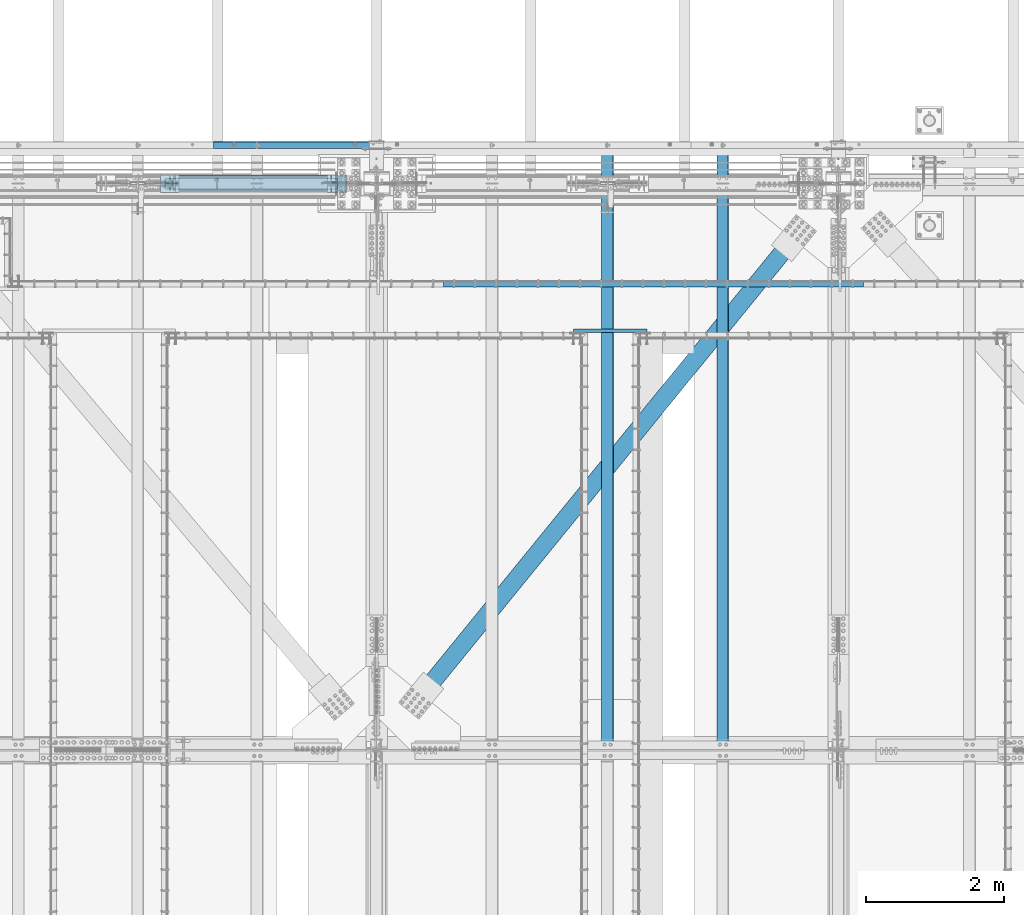
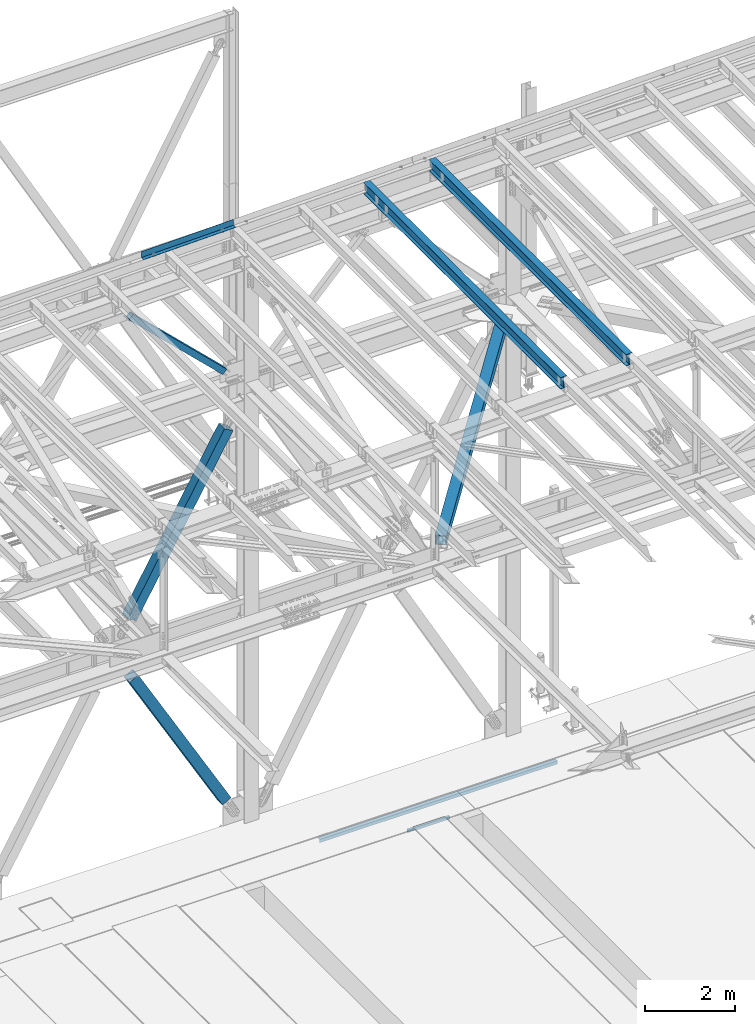
# One storey, part 1917 of 3843: 6 beams, 3 members, 9 elements without a shape of their own.
"""IFC2X3 building model written with IfcOpenShell, lengths in millimetres."""

from ifc_helpers import new_model, si_unit, frame, origin_with_axes, place, context, subcontext, project, spatial, faceted_brep, material, type_object, element, aggregate, save


model = new_model("IFC2X3")

# Units and contexts
model_context = context("Model", 3, precision=1e-05, world=origin_with_axes())
body_context = subcontext(model_context, "Body", "Model", "MODEL_VIEW")
ifc_project = project(units=[si_unit("LENGTHUNIT", "METRE", prefix="MILLI"), si_unit("AREAUNIT", "SQUARE_METRE"), si_unit("VOLUMEUNIT", "CUBIC_METRE"), si_unit("MASSUNIT", "GRAM", prefix="KILO"), si_unit("TIMEUNIT", "SECOND"), si_unit("PLANEANGLEUNIT", "RADIAN"), si_unit("SOLIDANGLEUNIT", "STERADIAN"), si_unit("THERMODYNAMICTEMPERATUREUNIT", "DEGREE_CELSIUS"), si_unit("LUMINOUSINTENSITYUNIT", "LUMEN")], contexts=[model_context])

# Site, building, storey
site_placement = place(None, origin_with_axes())
site = spatial("IfcSite", under=ifc_project, at=site_placement, CompositionType="ELEMENT")
building_placement = place(site_placement, origin_with_axes())
building = spatial("IfcBuilding", under=site, at=building_placement, Name="Undefined", CompositionType="ELEMENT")
storey_placement = place(building_placement, origin_with_axes())
storey = spatial("IfcBuildingStorey", under=building, at=storey_placement, Name="Undefined", CompositionType="ELEMENT", Elevation=0.0)

# Assembly, beam
assembly_1_placement = place(storey_placement, origin_with_axes())
assembly_1 = element("IfcElementAssembly", 1, at=assembly_1_placement, inside=storey, Name="EMBED_ANGLE", AssemblyPlace="NOTDEFINED", PredefinedType="RIGID_FRAME")
ifc_material_1 = material(Name="STEEL/A36")
beam_type_1 = type_object("IfcBeamType", Name="L3-1/2X3-1/2X5/16", PredefinedType="NOTDEFINED")
beam_1_placement = place(assembly_1_placement, frame((56903.1121552734, 90754.0730224609, 30410.15), z_axis=(0.0, 0.0, -1.0), x_axis=(1.0, 0.0, 0.0)))
beam_1 = element("IfcBeam", 2, at=beam_1_placement, type_object=beam_type_1, material=ifc_material_1, Name="EMBED_ANGLE", ObjectType="L3-1/2X3-1/2X5/16", context=body_context, shape_type="Brep", body=[
    faceted_brep([(-3.63797880709171e-12, 44.4499999999971, -44.4500000000007), (-3.63797880709171e-12, 44.4499999999971, 44.4500000000007), (6096.0, 44.4499999999971, 44.4500000000007), (6096.0, 44.4499999999971, -44.4500000000007), (-3.63797880709171e-12, 36.5124999999971, 44.4500000000007), (6096.0, 36.5124999999971, 44.4500000000007), (-3.63797880709171e-12, 36.5124999999971, -36.5125000000007), (6096.0, 36.5124999999971, -36.5125000000007), (3.63797880709171e-12, -44.4499999999971, -36.5125000000007), (6096.0, -44.4499999999971, -36.5125000000007), (3.63797880709171e-12, -44.4499999999971, -44.4500000000007), (6096.0, -44.4499999999971, -44.4500000000007)], [[[0, 1, 2, 3]], [[1, 4, 5, 2]], [[4, 6, 7, 5]], [[6, 8, 9, 7]], [[8, 10, 11, 9]], [[10, 0, 3, 11]], [[5, 7, 9, 11, 3, 2]], [[10, 8, 6, 4, 1, 0]]]),
])
aggregate(assembly_1, [beam_1])

assembly_2_placement = place(storey_placement, origin_with_axes())
assembly_2 = element("IfcElementAssembly", 3, at=assembly_2_placement, inside=storey, Name="BEAM", AssemblyPlace="NOTDEFINED", PredefinedType="RIGID_FRAME")
ifc_material_2 = material(Name="STEEL/A992")
beam_type_2 = type_object("IfcBeamType", Name="W12X26", PredefinedType="NOTDEFINED")
beam_2_placement = place(assembly_2_placement, frame((60956.7092623525, 83985.3070210652, 46101.5680546945), z_axis=(-0.0211520977430119, 0.00133068299971637, 0.999775383795693), x_axis=(0.0, 0.999999114244396, -0.00133098100032549)))
beam_2 = element("IfcBeam", 4, at=beam_2_placement, type_object=beam_type_2, material=ifc_material_2, Name="BEAM", ObjectType="W12X26", context=body_context, shape_type="Brep", body=[
    faceted_brep([(8748.72263270865, -3.17499999943539, -146.05000001414), (8748.72263270865, -82.5499999992899, -146.050000014278), (8748.72263270865, -82.549999999268, -155.575000014258), (8748.72263270864, 82.5500000004176, -155.575000013974), (8748.72263270865, 82.5500000003958, -146.050000013987), (8748.72263270865, 3.17500000055588, -146.050000014126), (8748.72263270925, 3.17500000054133, -142.875000025204), (8748.72263270922, -3.17499999944994, -142.875000025211), (8749.68936263188, 3.17500000054133, -138.014920507158), (8749.68936263185, -3.17499999945721, -138.014920507165), (8752.44237653237, 3.17500000052678, -133.894744038997), (8752.44237653234, -3.17499999945721, -133.894744039011), (8756.56255300052, 3.17500000052678, -131.141730138515), (8756.56255300048, -3.17499999947177, -131.14173013853), (8761.42263251852, 3.17500000052678, -130.175000215917), (8761.42263251847, -3.17499999946449, -130.175000215932), (8818.53642067379, -3.17499999946449, -130.175000214927), (8818.53659944578, 3.17500000052678, -130.175000214906), (12.2987329308962, 3.17499999972642, 146.049999999806), (12.3009675807116, 82.5499999995736, 146.049999999945), (8748.72263271244, 82.5499999998792, 146.049999985633), (8748.72263271244, 3.17500000002474, 146.049999985502), (12.6976871889201, -82.5499999995736, -155.574999999961), (12.6850124200719, -82.5499999995882, -146.049999999974), (12.6872470699018, -3.17499999974098, -146.049999999836), (12.2985541589005, -3.17500000025757, 146.049999999785), (12.2963195090852, -82.5500000001048, 146.049999999654), (12.2836447402515, -82.5500000001266, 155.574999999641), (12.2882928118779, 82.5499999995591, 155.574999999932), (12.6874258418829, 3.17500000025029, -146.049999999828), (12.6896604917129, 82.5500000000902, -146.049999999683), (12.7023352605465, 82.550000000112, -155.57499999967), (8748.72263271245, -3.17499999995198, 146.049999985487), (8748.72263271245, -82.5499999997992, 146.049999985349), (8748.72263271244, -82.549999999821, 155.574999985336), (8748.72263271244, 82.5499999998647, 155.574999985627), (8748.72263271274, -3.17499999995198, 142.874999592197), (8748.72263271277, 3.17500000004657, 142.874999592212), (8749.68936263525, -3.1749999999447, 138.014920074194), (8749.6893626353, 3.17500000003929, 138.014920074209), (8752.44237653565, -3.17499999993015, 133.894743606077), (8752.44237653566, 3.17500000005384, 133.894743606092), (8756.56255300369, -3.17499999993015, 131.141729705632), (8756.56255300372, 3.17500000005384, 131.14172970564), (8761.42263252163, -3.17499999992287, 130.174999783063), (8761.42263252167, 3.17500000005384, 130.17499978307), (8818.18997699225, -3.17499999992287, 130.174999782561), (8818.19015576423, 3.17500000006112, 130.174999782568), (8818.51385482927, 3.17500000049768, -113.082580227099), (8818.20699928008, 3.17500000009022, 117.517215612548)], [[[0, 1, 2, 3, 4, 5, 6, 7]], [[7, 6, 8, 9]], [[9, 8, 10, 11]], [[11, 10, 12, 13]], [[13, 12, 14, 15]], [[16, 15, 14, 17]], [[18, 19, 20, 21]], [[22, 23, 24, 25, 26, 27, 28, 19, 18, 29, 30, 31]], [[26, 25, 32, 33]], [[27, 26, 33, 34]], [[28, 27, 34, 35]], [[19, 28, 35, 20]], [[34, 33, 32, 36, 37, 21, 20, 35]], [[38, 39, 37, 36]], [[40, 41, 39, 38]], [[42, 43, 41, 40]], [[44, 45, 43, 42]], [[46, 47, 45, 44]], [[48, 49, 47, 46, 16, 17]], [[12, 10, 8, 6, 5, 29, 18, 21, 37, 39, 41, 43, 45, 47, 49, 48, 17, 14]], [[30, 29, 5, 4]], [[31, 30, 4, 3]], [[22, 31, 3, 2]], [[23, 22, 2, 1]], [[24, 23, 1, 0]], [[46, 44, 42, 40, 38, 36, 32, 25, 24, 0, 7, 9, 11, 13, 15, 16]]]),
])
aggregate(assembly_2, [beam_2])

assembly_3_placement = place(storey_placement, origin_with_axes())
assembly_3 = element("IfcElementAssembly", 5, at=assembly_3_placement, inside=storey, Name="BEAM", AssemblyPlace="NOTDEFINED", PredefinedType="RIGID_FRAME")
beam_3_placement = place(assembly_3_placement, frame((59280.3092623558, 83985.2927883215, 46065.291925537), z_axis=(-0.0211520982558723, 0.0012391990004544, 0.999775501362787), x_axis=(0.0, 0.999999231849328, -0.00123947599981323)))
beam_3 = element("IfcBeam", 6, at=beam_3_placement, type_object=beam_type_2, material=ifc_material_2, Name="BEAM", ObjectType="W12X26", context=body_context, shape_type="Brep", body=[
    faceted_brep([(8748.72143649217, -3.17500000043947, -146.049999982926), (8748.72143649215, -82.5500000003012, -146.049999982824), (8748.72143649215, -82.5500000003085, -155.574999982826), (8748.72143649217, 82.5499999994281, -155.574999983044), (8748.72143649214, 82.5499999994354, -146.04999998305), (8748.72143649215, 3.17499999955908, -146.049999982941), (8748.72143649243, 3.17499999955908, -142.874999394546), (8748.72143649241, -3.17500000043219, -142.874999394531), (8749.68816641509, 3.17499999956635, -138.014919876499), (8749.68816641506, -3.17500000042492, -138.014919876478), (8752.4411803156, 3.17499999956635, -133.894743408324), (8752.44118031558, -3.17500000043219, -133.894743408309), (8756.56135678376, 3.17499999956635, -131.141729507806), (8756.56135678376, -3.17500000042492, -131.141729507792), (8761.42143630181, 3.17499999957363, -130.174999585171), (8761.4214363018, -3.17500000041764, -130.174999585157), (8818.53771352515, -3.17500000042492, -130.174999583222), (8818.53788000652, 3.17499999955908, -130.174999583236), (12.3263194197789, 3.17500000007567, 146.05000000001), (12.3284004369925, 82.5499999999447, 146.049999999901), (8748.72143649191, 82.5499999995882, 146.05000001692), (8748.72143649189, 3.17499999971915, 146.050000017021), (12.6978455112549, -82.549999999952, -155.574999999837), (12.6860421347228, -82.5499999999447, -146.049999999843), (12.6881231519219, -3.17500000008295, -146.049999999945), (12.3261529384181, -3.1749999999156, 146.050000000017), (12.3240719212044, -82.5499999997919, 146.050000000119), (12.312268544687, -82.5499999997919, 155.575000000114), (12.3165970604459, 82.549999999952, 155.574999999903), (12.6882896332972, 3.1749999999156, -146.049999999959), (12.6903706504963, 82.5499999997919, -146.050000000068), (12.7021740270138, 82.5499999997846, -155.57500000007), (8748.72143649189, -3.17500000027212, 146.050000017021), (8748.72143649189, -82.5500000001412, 146.050000017138), (8748.72143649186, -82.5500000001412, 155.575000017132), (8748.72143649189, 82.5499999995882, 155.575000016914), (8748.7214364918, -3.17500000027212, 142.875000223874), (8748.72143649182, 3.17499999971187, 142.875000223859), (8749.68816641431, -3.1750000002794, 138.014920705842), (8749.68816641434, 3.17499999971187, 138.01492070582), (8752.44118031474, -3.1750000002794, 133.894744237718), (8752.44118031477, 3.17499999971187, 133.894744237703), (8756.56135678284, -3.17500000028667, 131.141730337273), (8756.56135678286, 3.1749999997046, 131.141730337265), (8761.42143630084, -3.1750000002794, 130.17500041474), (8761.42143630087, 3.1749999997046, 130.175000414718), (8818.21508790005, -3.1750000002794, 130.175000414572), (8818.21525438143, 3.1749999997046, 130.175000414565), (8818.5167027141, 3.17499999957363, -113.085507448035), (8818.23094349758, 3.17499999969732, 117.514315490778)], [[[0, 1, 2, 3, 4, 5, 6, 7]], [[7, 6, 8, 9]], [[9, 8, 10, 11]], [[11, 10, 12, 13]], [[13, 12, 14, 15]], [[16, 15, 14, 17]], [[18, 19, 20, 21]], [[22, 23, 24, 25, 26, 27, 28, 19, 18, 29, 30, 31]], [[26, 25, 32, 33]], [[27, 26, 33, 34]], [[28, 27, 34, 35]], [[19, 28, 35, 20]], [[34, 33, 32, 36, 37, 21, 20, 35]], [[38, 39, 37, 36]], [[40, 41, 39, 38]], [[42, 43, 41, 40]], [[44, 45, 43, 42]], [[46, 47, 45, 44]], [[48, 49, 47, 46, 16, 17]], [[12, 10, 8, 6, 5, 29, 18, 21, 37, 39, 41, 43, 45, 47, 49, 48, 17, 14]], [[30, 29, 5, 4]], [[31, 30, 4, 3]], [[22, 31, 3, 2]], [[23, 22, 2, 1]], [[24, 23, 1, 0]], [[46, 44, 42, 40, 38, 36, 32, 25, 24, 0, 7, 9, 11, 13, 15, 16]]]),
])
aggregate(assembly_3, [beam_3])

assembly_4_placement = place(storey_placement, origin_with_axes())
assembly_4 = element("IfcElementAssembly", 7, at=assembly_4_placement, inside=storey, Name="CHANNEL", AssemblyPlace="NOTDEFINED", PredefinedType="RIGID_FRAME")
beam_type_3 = type_object("IfcBeamType", PredefinedType="NOTDEFINED")
beam_4_placement = place(assembly_4_placement, frame((54742.558037009, 92722.6999766365, 46117.1171459536), z_axis=(0.999776270257024, 0.0, 0.0211520550054619), x_axis=(0.0, 1.0, 0.0)))
beam_4 = element("IfcBeam", 8, at=beam_4_placement, type_object=beam_type_3, material=ifc_material_1, Name="BENT_PLATE", context=body_context, shape_type="Brep", body=[
    faceted_brep([(9.31322574615479e-10, 5.47515810467303e-08, -1181.89399999808), (-5.38420863449574e-10, 3.17499999882421, -1178.71900003228), (95.2499985702016, 3.17500004347676, -1178.71900003266), (98.4249985454371, 1.00902980193496e-07, -1181.89399999846), (95.2499985053, 161.925001484902, -1178.71900003352), (98.4249984792696, 161.925001486248, -1181.89399999885), (95.2499985716568, 3.17500004584144, 1181.89399999772), (95.2499985032919, 161.925001490621, 1181.89399999733), (2.40106601268053e-09, -3.17500000117434, -1181.89399999807), (5.0931703299284e-10, -3.17499999881693, 1181.8939999981), (-2.43016984313726e-09, 3.17500000118162, 1181.89399999809), (101.599998572856, -3.17499995353865, -1181.89399999847), (101.599998574326, -3.17499995117396, 1181.89399999771), (101.599998503283, 161.925001493335, 1181.89399999731), (101.59999850532, 161.925001487602, -1181.89399999887)], [[[0, 1, 2, 3]], [[3, 2, 4, 5]], [[6, 7, 4, 2]], [[8, 9, 10, 1, 0]], [[10, 6, 2, 1]], [[9, 8, 11, 12]], [[6, 10, 9, 12, 13, 7]], [[12, 11, 14, 13]], [[14, 11, 8, 0, 3, 5]], [[7, 13, 14, 5, 4]]]),
])
aggregate(assembly_4, [beam_4])

# Assembly, member
assembly_5_placement = place(storey_placement, origin_with_axes())
assembly_5 = element("IfcElementAssembly", 9, at=assembly_5_placement, inside=storey, Name="None", AssemblyPlace="NOTDEFINED", PredefinedType="RIGID_FRAME")
member_type_1 = type_object("IfcMemberType", Name="HSS10X10X1/4", PredefinedType="NOTDEFINED")
member_1_placement = place(assembly_5_placement, frame((55326.4100772081, 92214.7, 31204.991746486), z_axis=(0.0, 1.0, 0.0), x_axis=(-0.497020968229067, 0.0, 0.867738530399936)))
member_1 = element("IfcMember", 10, at=member_1_placement, type_object=member_type_1, material=ifc_material_2, Name="None", ObjectType="HSS10X10X1/4", context=body_context, shape_type="Brep", body=[
    faceted_brep([(2.00088834390044e-10, 120.650000000089, -120.649999999994), (-2.03726813197136e-10, -120.650000000081, -120.649999999994), (4781.54999999434, -120.649999998248, -120.649999999994), (4781.54999999471, 120.650000000955, -120.649999999994), (-2.03726813197136e-10, -120.650000000081, 120.649999999994), (4781.54999999434, -120.649999998248, 120.649999999994), (2.00088834390044e-10, 120.650000000089, 120.649999999994), (4781.54999999471, 120.650000000955, 120.649999999994), (2.16459739021957e-10, 127.000000000087, -127.0), (2.16459739021957e-10, 127.000000000087, 127.0), (4781.54999999471, 127.000000000939, 127.0), (4781.54999999471, 127.000000000939, -127.0), (-2.14640749618411e-10, -127.00000000008, 127.0), (4781.54999999432, -126.999999998225, 127.0), (-2.14640749618411e-10, -127.00000000008, -127.0), (4781.54999999432, -126.999999998225, -127.0)], [[[0, 1, 2, 3]], [[1, 4, 5, 2]], [[4, 6, 7, 5]], [[6, 0, 3, 7]], [[8, 9, 10, 11]], [[9, 12, 13, 10]], [[12, 14, 15, 13]], [[14, 8, 11, 15]], [[13, 15, 11, 10], [5, 7, 3, 2]], [[14, 12, 9, 8], [6, 4, 1, 0]]]),
])
aggregate(assembly_5, [member_1])

assembly_6_placement = place(storey_placement, origin_with_axes())
assembly_6 = element("IfcElementAssembly", 11, at=assembly_6_placement, inside=storey, Name="None", AssemblyPlace="NOTDEFINED", PredefinedType="RIGID_FRAME")
member_2_placement = place(assembly_6_placement, frame((52902.4412831752, 92214.7, 36961.4938626136), z_axis=(0.0, -1.0, 0.0), x_axis=(0.500674758933455, 0.0, 0.865635480884955)))
member_2 = element("IfcMember", 12, at=member_2_placement, type_object=member_type_1, material=ifc_material_2, Name="None", ObjectType="HSS10X10X1/4", context=body_context, shape_type="Brep", body=[
    faceted_brep([(2.00088834390044e-10, 120.650000000089, -120.649999999994), (-2.03726813197136e-10, -120.650000000081, -120.649999999994), (4946.65074268766, -120.650000011752, -120.649999999994), (4946.65074268823, 120.649999988462, -120.649999999994), (-2.03726813197136e-10, -120.650000000081, 120.649999999994), (4946.65074268766, -120.650000011752, 120.649999999994), (2.00088834390044e-10, 120.650000000089, 120.649999999994), (4946.65074268823, 120.649999988462, 120.649999999994), (2.16459739021957e-10, 127.000000000087, -127.0), (2.16459739021957e-10, 127.000000000087, 127.0), (4946.65074268825, 126.999999988468, 127.0), (4946.65074268825, 126.999999988468, -127.0), (-2.14640749618411e-10, -127.00000000008, 127.0), (4946.65074268765, -127.000000011751, 127.0), (-2.14640749618411e-10, -127.00000000008, -127.0), (4946.65074268765, -127.000000011751, -127.0)], [[[0, 1, 2, 3]], [[1, 4, 5, 2]], [[4, 6, 7, 5]], [[6, 0, 3, 7]], [[8, 9, 10, 11]], [[9, 12, 13, 10]], [[12, 14, 15, 13]], [[14, 8, 11, 15]], [[13, 15, 11, 10], [5, 7, 3, 2]], [[14, 12, 9, 8], [6, 4, 1, 0]]]),
])
aggregate(assembly_6, [member_2])

assembly_7_placement = place(storey_placement, origin_with_axes())
assembly_7 = element("IfcElementAssembly", 13, at=assembly_7_placement, inside=storey, AssemblyPlace="NOTDEFINED", PredefinedType="RIGID_FRAME")
ifc_material_3 = material()
member_type_2 = type_object("IfcMemberType", Name="HSS6X6X3/8", PredefinedType="NOTDEFINED")
member_3_placement = place(assembly_7_placement, frame((52463.7000016374, 92214.700000217, 45546.4993567762), z_axis=(0.694768099788301, 0.0, 0.719233819780851), x_axis=(0.719233819780852, 0.0, -0.6947680997883)))
member_3 = element("IfcMember", 14, at=member_3_placement, type_object=member_type_2, material=ifc_material_3, ObjectType="HSS6X6X3/8", context=body_context, shape_type="Brep", body=[
    faceted_brep([(620.08024611968, 7.93749962873699, 76.199999997727), (620.08024611968, 7.93749962873699, 66.6749999977328), (720.092746119906, 7.93749962873699, 66.6749999973545), (720.092746119935, 7.93749962873699, 76.1999999973486), (723.130295864306, 7.33329341805074, 66.6749999973545), (723.130295864343, 7.33329341805074, 76.1999999973486), (725.705406195579, 5.61265970440581, 66.6749999973399), (725.705406195608, 5.61265970440581, 76.1999999973486), (727.426039909205, 3.03754937314079, 66.6749999973254), (727.426039909242, 3.03754937314079, 76.1999999973341), (720.092746119935, -7.93750037126301, 76.1999999973486), (720.092746119906, -7.93750037126301, 66.6749999973545), (620.08024611968, -7.93750037126301, 66.6749999977328), (620.08024611968, -7.93750037126301, 76.199999997727), (723.130295864343, -7.33329416057677, 76.1999999973486), (723.130295864306, -7.33329416057677, 66.6749999973545), (725.705406195608, -5.61266044693184, 76.1999999973486), (725.705406195579, -5.61266044693184, 66.6749999973399), (727.426039909242, -3.03755011566682, 76.1999999973341), (727.426039909205, -3.03755011566682, 66.6749999973254), (728.030246119943, -3.71263013221323e-07, 76.1999999973195), (728.030246119906, -3.71263013221323e-07, 66.6749999973254), (620.080246119684, 7.93749962873699, -66.675000002273), (620.08024611968, 7.93749962873699, -76.2000000022817), (720.092746119375, 7.93749962873699, -76.2000000026455), (720.092746119411, 7.93749962873699, -66.6750000026514), (723.130295863779, 7.33329341805074, -76.2000000026601), (723.130295863808, 7.33329341805074, -66.6750000026514), (725.705406195044, 5.61265970440581, -76.2000000026746), (725.70540619508, 5.61265970440581, -66.6750000026659), (727.426039908685, 3.03754937314079, -76.2000000026746), (727.426039908722, 3.03754937314079, -66.6750000026805), (720.092746119411, -7.93750037126301, -66.6750000026514), (720.092746119375, -7.93750037126301, -76.2000000026455), (620.08024611968, -7.93750037126301, -76.2000000022817), (620.080246119684, -7.93750037126301, -66.675000002273), (723.130295863808, -7.33329416057677, -66.6750000026514), (723.130295863779, -7.33329416057677, -76.2000000026601), (725.70540619508, -5.61266044693184, -66.6750000026659), (725.705406195044, -5.61266044693184, -76.2000000026746), (727.426039908722, -3.03755011566682, -66.6750000026805), (727.426039908685, -3.03755011566682, -76.2000000026746), (728.030246119411, -3.71263013221323e-07, -66.6750000026805), (728.030246119379, -3.71263013221323e-07, -76.2000000026746), (620.08024611968, 66.6750000000029, 66.6749999977328), (620.080246119684, 66.6750000000029, -66.675000002273), (3951.34992310517, 66.6750000000029, -66.6750000145257), (3951.34992310518, 66.6750000000029, 66.6749999854801), (620.08024611968, 76.1999999999971, -76.2000000022817), (3951.34992310518, 76.1999999999971, -76.2000000145199), (3951.34992310518, 20.6374999999971, -76.2000000145199), (3851.33742310282, 20.6374999999971, -76.2000000141707), (3848.29987335841, 20.0332937893108, -76.2000000141416), (3845.72476302715, 18.3126600756659, -76.2000000141416), (3844.0041293135, 15.7375497444009, -76.2000000141416), (3843.39992310281, 12.6999999999971, -76.200000014127), (3844.0041293135, 9.66245025559328, -76.2000000141416), (3845.72476302715, 7.08733992432826, -76.2000000141416), (3848.29987335841, 5.36670621068333, -76.2000000141416), (3851.33742310282, 4.76249999999709, -76.2000000141707), (3951.34992310518, 4.76249999999709, -76.2000000145199), (3951.34992310518, -76.1999999999971, -76.2000000145199), (620.08024611968, -76.1999999999971, -76.2000000022817), (3951.34992310517, 20.6374999999971, -66.6750000145257), (3851.33742310284, 20.6374999999971, -66.6750000141619), (3848.29987335845, 20.0332937893108, -66.6750000141474), (3845.72476302717, 18.3126600756659, -66.6750000141328), (3844.00412931354, 15.7375497444009, -66.6750000141328), (3843.39992310284, 12.6999999999971, -66.6750000141328), (3844.00412931354, 9.66245025559328, -66.6750000141328), (3845.72476302717, 7.08733992432826, -66.6750000141328), (3848.29987335845, 5.36670621068333, -66.6750000141474), (3851.33742310284, 4.76249999999709, -66.6750000141619), (3951.34992310517, 4.76249999999709, -66.6750000145257), (620.080246119684, -66.6750000000029, -66.675000002273), (620.08024611968, -66.6750000000029, 66.6749999977328), (3951.34992310518, -66.6750000000029, 66.6749999854801), (3951.34992310517, -66.6750000000029, -66.6750000145257), (3848.29987335897, 20.0332937893108, 76.1999999858526), (3848.29987335894, 20.0332937893108, 66.6749999858584), (3851.33742310334, 20.6374999999971, 66.6749999858439), (3851.33742310337, 20.6374999999971, 76.1999999858381), (3845.72476302771, 18.3126600756659, 76.1999999858672), (3845.72476302767, 18.3126600756659, 66.6749999858584), (3844.00412931406, 15.7375497444009, 76.1999999858672), (3844.00412931402, 15.7375497444009, 66.6749999858584), (3843.39992310337, 12.6999999999971, 76.1999999858817), (3843.39992310334, 12.6999999999971, 66.674999985873), (3844.00412931406, 9.66245025559328, 76.1999999858672), (3844.00412931402, 9.66245025559328, 66.6749999858584), (3845.72476302771, 7.08733992432826, 76.1999999858672), (3845.72476302767, 7.08733992432826, 66.6749999858584), (3848.29987335897, 5.36670621068333, 76.1999999858526), (3848.29987335894, 5.36670621068333, 66.6749999858584), (3851.33742310337, 4.76249999999709, 76.1999999858381), (3851.33742310334, 4.76249999999709, 66.6749999858439), (3951.34992310518, 4.76249999999709, 76.1999999854743), (3951.34992310518, 4.76249999999709, 66.6749999854801), (3951.34992310518, -76.1999999999971, 76.1999999854743), (620.08024611968, -76.1999999999971, 76.199999997727), (3951.34992310518, 20.6374999999971, 66.6749999854801), (3951.34992310518, 20.6374999999971, 76.1999999854743), (3951.34992310518, 76.1999999999971, 76.1999999854743), (620.08024611968, 76.1999999999971, 76.199999997727)], [[[0, 1, 2, 3]], [[3, 2, 4, 5]], [[5, 4, 6, 7]], [[7, 6, 8, 9]], [[10, 11, 12, 13]], [[14, 15, 11, 10]], [[16, 17, 15, 14]], [[18, 19, 17, 16]], [[20, 21, 19, 18]], [[9, 8, 21, 20]], [[22, 23, 24, 25]], [[25, 24, 26, 27]], [[27, 26, 28, 29]], [[29, 28, 30, 31]], [[32, 33, 34, 35]], [[36, 37, 33, 32]], [[38, 39, 37, 36]], [[40, 41, 39, 38]], [[42, 43, 41, 40]], [[31, 30, 43, 42]], [[44, 45, 46, 47]], [[28, 26, 24, 23, 48, 49, 50, 51, 52, 53, 54, 55, 56, 57, 58, 59, 60, 61, 62, 34, 33, 37, 39, 41, 43, 30]], [[63, 64, 51, 50]], [[65, 52, 51, 64]], [[66, 53, 52, 65]], [[67, 54, 53, 66]], [[68, 55, 54, 67]], [[69, 56, 55, 68]], [[70, 57, 56, 69]], [[71, 58, 57, 70]], [[72, 59, 58, 71]], [[73, 60, 59, 72]], [[74, 75, 76, 77]], [[78, 79, 80, 81]], [[82, 83, 79, 78]], [[84, 85, 83, 82]], [[86, 87, 85, 84]], [[88, 89, 87, 86]], [[90, 91, 89, 88]], [[92, 93, 91, 90]], [[94, 95, 93, 92]], [[96, 97, 95, 94]], [[98, 61, 60, 73, 77, 76, 97, 96]], [[99, 62, 61, 98]], [[75, 74, 35, 34, 62, 99, 13, 12]], [[6, 4, 2, 1, 44, 47, 100, 80, 79, 83, 85, 87, 89, 91, 93, 95, 97, 76, 75, 12, 11, 15, 17, 19, 21, 8]], [[101, 81, 80, 100]], [[47, 46, 63, 50, 49, 102, 101, 100]], [[48, 103, 102, 49]], [[16, 14, 10, 13, 99, 98, 96, 94, 92, 90, 88, 86, 84, 82, 78, 81, 101, 102, 103, 0, 3, 5, 7, 9, 20, 18]], [[103, 48, 23, 22, 45, 44, 1, 0]], [[38, 36, 32, 35, 74, 77, 73, 72, 71, 70, 69, 68, 67, 66, 65, 64, 63, 46, 45, 22, 25, 27, 29, 31, 42, 40]]]),
])
aggregate(assembly_7, [member_3])

# Assembly, beam
assembly_8_placement = place(storey_placement, origin_with_axes())
assembly_8 = element("IfcElementAssembly", 15, at=assembly_8_placement, inside=storey, AssemblyPlace="NOTDEFINED", PredefinedType="RIGID_FRAME")
beam_type_4 = type_object("IfcBeamType", Name="HSS10X10X3/4", PredefinedType="NOTDEFINED")
beam_5_placement = place(assembly_8_placement, frame((55930.8, 83985.1, 42246.55), z_axis=(0.775234985789335, -0.631672950828361, 0.0), x_axis=(0.631672950828353, 0.775234985789342, 0.0)))
beam_5 = element("IfcBeam", 16, at=beam_5_placement, type_object=beam_type_4, material=ifc_material_3, ObjectType="HSS10X10X3/4", context=body_context, shape_type="Brep", body=[
    faceted_brep([(9560.48374436072, 26.9874999999956, 126.99999996714), (9308.07124474258, 26.9874999999956, 126.999999967999), (9308.07124474252, 26.9874999999956, 107.949999968017), (9560.48374436071, 26.9874999999956, 107.949999967152), (9302.60365505669, 25.8999287917104, 126.99999996802), (9302.60365505662, 25.8999287917104, 107.949999968032), (9297.96845633665, 22.8027880244699, 126.999999968042), (9297.96845633659, 22.8027880244699, 107.949999968054), (9294.87131556941, 18.167589304423, 126.999999968042), (9294.87131556935, 18.167589304423, 107.949999968061), (9293.78374436114, 12.6999996185259, 126.999999968049), (9293.78374436108, 12.6999996185259, 107.949999968061), (9294.87131556941, 7.23241069557116, 126.999999968042), (9294.87131556935, 7.23241069557116, 107.949999968061), (9297.96845633665, 2.59721197552426, 126.999999968042), (9297.96845633659, 2.59721197552426, 107.949999968054), (9302.60365505669, -0.499928791716229, 126.99999996802), (9302.60365505662, -0.499928791716229, 107.949999968032), (9308.07124474258, -1.58750000000146, 126.999999967999), (9308.07124474252, -1.58750000000146, 107.949999968017), (9560.48374436072, -1.58750000000146, 126.99999996714), (9560.48374436071, -1.58750000000146, 107.949999967152), (9560.48374436071, 26.9874999999956, -107.950000032719), (9308.07124474176, 26.9874999999956, -107.950000031853), (9308.0712447417, 26.9874999999956, -127.000000031841), (9560.48374436072, 26.9874999999956, -127.000000032707), (9302.60365505589, 25.8999287917104, -107.950000031831), (9302.60365505583, 25.8999287917104, -127.000000031827), (9297.96845633586, 22.8027880244699, -107.950000031817), (9297.9684563358, 22.8027880244699, -127.000000031805), (9294.8713155686, 18.167589304423, -107.950000031802), (9294.87131556854, 18.167589304423, -127.000000031798), (9293.78374436033, 12.6999996185259, -107.950000031802), (9293.78374436026, 12.6999996185259, -127.00000003179), (9294.8713155686, 7.23241069557116, -107.950000031802), (9294.87131556854, 7.23241069557116, -127.000000031798), (9297.96845633586, 2.59721197552426, -107.950000031817), (9297.9684563358, 2.59721197552426, -127.000000031805), (9302.60365505589, -0.499928791716229, -107.950000031831), (9302.60365505583, -0.499928791716229, -127.000000031827), (9308.07124474176, -1.58750000000146, -107.950000031853), (9308.0712447417, -1.58750000000146, -127.000000031841), (9560.48374436071, -1.58750000000146, -107.950000032719), (9560.48374436072, -1.58750000000146, -127.000000032707), (1055.13624486455, 107.949999999997, 107.950000001496), (1055.13624486455, 107.949999999997, -107.949999998869), (9560.48373308785, 107.949999999997, -107.949999988334), (9560.48373308784, 107.949999999997, 107.950000012024), (9560.48373308784, -107.949999999997, 107.950000012024), (1055.13624486455, -107.949999999997, 107.950000001496), (1055.1362453918, -1.58750000063446, 107.949999996314), (1307.54874501264, -1.58750000063446, 107.949999995455), (1313.01633469851, -0.499928792349237, 107.949999995433), (1317.65153341855, 2.59721197489125, 107.949999995419), (1320.7486741858, 7.23241069493815, 107.949999995404), (1321.83624539408, 12.6999996178929, 107.949999995397), (1320.7486741858, 18.16758930379, 107.949999995404), (1317.65153341855, 22.8027880238369, 107.949999995419), (1313.01633469851, 25.8999287910774, 107.949999995433), (1307.54874501264, 26.9874999993626, 107.949999995455), (1055.1362453918, 26.9874999993626, 107.949999996314), (1055.13624486455, -107.949999999997, -107.949999998869), (9560.48373308785, -107.949999999997, -107.949999988334), (1055.13624539181, 26.9874999993626, -107.950000003557), (1307.54874501188, 26.9874999993626, -107.950000004415), (1313.01633469778, 25.8999287910774, -107.950000004437), (1317.65153341781, 22.8027880238369, -107.950000004452), (1320.74867418504, 18.16758930379, -107.950000004459), (1321.83624539332, 12.6999996178929, -107.950000004474), (1320.74867418504, 7.23241069493815, -107.950000004459), (1317.65153341781, 2.59721197489125, -107.950000004452), (1313.01633469778, -0.499928792349237, -107.950000004437), (1307.54874501188, -1.58750000063446, -107.950000004415), (1055.13624539181, -1.58750000063446, -107.950000003557), (1055.1362453918, 26.9874999993626, -127.000000003531), (1307.54874501182, 26.9874999993626, -127.000000004404), (1313.01633469772, 25.8999287910774, -127.000000004418), (1317.65153341775, 22.8027880238369, -127.000000004447), (1320.74867418499, 18.16758930379, -127.000000004455), (1321.83624539326, 12.6999996178929, -127.000000004447), (1320.74867418499, 7.23241069493815, -127.000000004455), (1317.65153341775, 2.59721197489125, -127.000000004447), (1313.01633469772, -0.499928792349237, -127.000000004418), (1307.54874501182, -1.58750000063446, -127.000000004404), (1055.1362453918, -1.58750000063446, -127.000000003531), (1055.13624486455, -127.0, -126.999999998901), (1055.13624486455, -127.0, 127.000000001521), (1055.1362453918, -1.58750000063446, 126.999999996302), (1307.5487450127, -1.58750000063446, 126.999999995443), (1313.01633469859, -0.499928792349237, 126.999999995414), (1317.65153341863, 2.59721197489125, 126.9999999954), (1320.74867418586, 7.23241069493815, 126.999999995392), (1321.83624539414, 12.6999996178929, 126.999999995392), (1320.74867418586, 18.16758930379, 126.999999995392), (1317.65153341863, 22.8027880238369, 126.9999999954), (1313.01633469859, 25.8999287910774, 126.999999995414), (1307.5487450127, 26.9874999993626, 126.999999995443), (1055.1362453918, 26.9874999993626, 126.999999996302), (1055.13624486455, 127.0, 127.000000001521), (1055.13624486455, 127.0, -126.999999998901), (9560.48373308783, 127.0, 127.000000012056), (9560.48373308784, 127.0, -126.99999998838), (9560.48373308784, -127.0, -126.99999998838), (9560.48373308783, -127.0, 127.000000012056)], [[[0, 1, 2, 3]], [[4, 5, 2, 1]], [[6, 7, 5, 4]], [[8, 9, 7, 6]], [[10, 11, 9, 8]], [[12, 13, 11, 10]], [[14, 15, 13, 12]], [[16, 17, 15, 14]], [[18, 19, 17, 16]], [[20, 21, 19, 18]], [[22, 23, 24, 25]], [[26, 27, 24, 23]], [[28, 29, 27, 26]], [[30, 31, 29, 28]], [[32, 33, 31, 30]], [[34, 35, 33, 32]], [[36, 37, 35, 34]], [[38, 39, 37, 36]], [[40, 41, 39, 38]], [[42, 43, 41, 40]], [[44, 45, 46, 47]], [[48, 49, 50, 51, 52, 53, 54, 55, 56, 57, 58, 59, 60, 44, 47, 3, 2, 5, 7, 9, 11, 13, 15, 17, 19, 21]], [[61, 49, 48, 62]], [[38, 36, 34, 32, 30, 28, 26, 23, 22, 46, 45, 63, 64, 65, 66, 67, 68, 69, 70, 71, 72, 73, 61, 62, 42, 40]], [[63, 74, 75, 64]], [[64, 75, 76, 65]], [[65, 76, 77, 66]], [[66, 77, 78, 67]], [[67, 78, 79, 68]], [[68, 79, 80, 69]], [[69, 80, 81, 70]], [[70, 81, 82, 71]], [[71, 82, 83, 72]], [[72, 83, 84, 73]], [[49, 61, 73, 84, 85, 86, 87, 50]], [[88, 51, 50, 87]], [[89, 52, 51, 88]], [[90, 53, 52, 89]], [[91, 54, 53, 90]], [[92, 55, 54, 91]], [[93, 56, 55, 92]], [[94, 57, 56, 93]], [[95, 58, 57, 94]], [[96, 59, 58, 95]], [[97, 60, 59, 96]], [[98, 99, 74, 63, 45, 44, 60, 97]], [[99, 98, 100, 101]], [[47, 46, 22, 25, 101, 100, 0, 3]], [[102, 85, 84, 83, 82, 81, 80, 79, 78, 77, 76, 75, 74, 99, 101, 25, 24, 27, 29, 31, 33, 35, 37, 39, 41, 43]], [[86, 85, 102, 103]], [[16, 14, 12, 10, 8, 6, 4, 1, 0, 100, 98, 97, 96, 95, 94, 93, 92, 91, 90, 89, 88, 87, 86, 103, 20, 18]], [[103, 102, 43, 42, 62, 48, 21, 20]]]),
])
aggregate(assembly_8, [beam_5])

assembly_9_placement = place(storey_placement, origin_with_axes())
assembly_9 = element("IfcElementAssembly", 17, at=assembly_9_placement, inside=storey, Name="COVER PLATE", AssemblyPlace="NOTDEFINED", PredefinedType="RIGID_FRAME")
beam_type_5 = type_object("IfcBeamType", PredefinedType="NOTDEFINED")
beam_6_placement = place(assembly_9_placement, frame((58789.0619257153, 90074.6232942286, 30416.5), z_axis=(0.0, 0.0, 1.0), x_axis=(1.0, 0.0, 0.0)))
beam_6 = element("IfcBeam", 18, at=beam_6_placement, type_object=beam_type_5, material=ifc_material_1, Name="COVER PLATE", context=body_context, shape_type="Brep", body=[
    faceted_brep([(0.0, 25.4000000000015, -38.0999999999985), (0.0, 25.4000000000015, 38.0999999999985), (1066.79998437835, 25.3999999999942, 38.0999999999985), (1066.79998437835, 25.3999999999942, -38.0999999999985), (0.0, -25.4000000000015, 38.0999999999985), (1066.79998437835, -25.3999999999942, 38.0999999999985), (0.0, -25.4000000000015, -38.0999999999985), (1066.79998437835, -25.3999999999942, -38.0999999999985)], [[[0, 1, 2, 3]], [[1, 4, 5, 2]], [[4, 6, 7, 5]], [[6, 0, 3, 7]], [[5, 7, 3, 2]], [[6, 4, 1, 0]]]),
])
aggregate(assembly_9, [beam_6])

save(model, "model.ifc")
